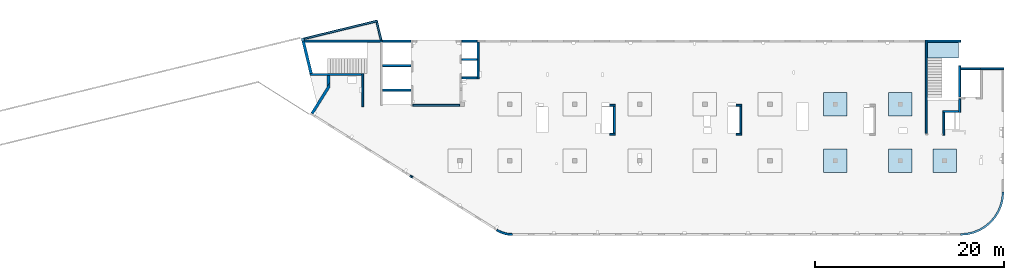
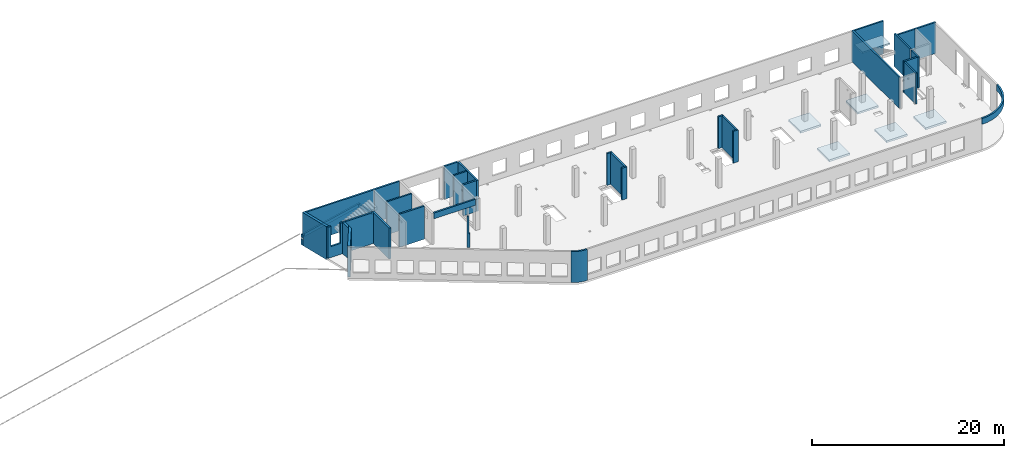
# One storey, part 2 of 7: 34 walls, 6 slabs, 2 openings.
"""IFC4 building model written with IfcOpenShell, lengths in millimetres."""

from ifc_helpers import new_model, entity, si_unit, converted_unit, derived_unit, direction, frame, origin, place, context, subcontext, project, spatial, indexed_curve, outline, extrude, polygons, material, type_object, element, save


model = new_model("IFC4")

# Units and contexts
model_context = context("Model", 3, precision=0.01, world=origin(), true_north=direction((6.12303176911189e-17, 1.0)))
plan_context = context("Plan", 3, precision=0.01, world=origin(), true_north=direction((6.12303176911189e-17, 1.0)))
body_context = subcontext(model_context, "Body", "Model", "MODEL_VIEW")
ifc_project = project(units=[si_unit("LENGTHUNIT", "METRE", prefix="MILLI"), si_unit("AREAUNIT", "SQUARE_METRE"), si_unit("VOLUMEUNIT", "CUBIC_METRE"), converted_unit("PLANEANGLEUNIT", "DEGREE", entity("IfcRatioMeasure", 0.0174532925199433), si_unit("PLANEANGLEUNIT", "RADIAN"), dimensions=[0, 0, 0, 0, 0, 0, 0]), si_unit("MASSUNIT", "GRAM", prefix="KILO"), derived_unit("MASSDENSITYUNIT", [(si_unit("MASSUNIT", "GRAM", prefix="KILO"), 1), (si_unit("LENGTHUNIT", "METRE"), -3)]), derived_unit("MOMENTOFINERTIAUNIT", [(si_unit("LENGTHUNIT", "METRE"), 4)]), si_unit("TIMEUNIT", "SECOND"), si_unit("FREQUENCYUNIT", "HERTZ"), si_unit("THERMODYNAMICTEMPERATUREUNIT", "DEGREE_CELSIUS"), derived_unit("THERMALTRANSMITTANCEUNIT", [(si_unit("MASSUNIT", "GRAM", prefix="KILO"), 1), (si_unit("THERMODYNAMICTEMPERATUREUNIT", "KELVIN"), -1), (si_unit("TIMEUNIT", "SECOND"), -3)]), derived_unit("VOLUMETRICFLOWRATEUNIT", [(si_unit("LENGTHUNIT", "METRE"), 3), (si_unit("TIMEUNIT", "SECOND"), -1)]), derived_unit("MASSFLOWRATEUNIT", [(si_unit("MASSUNIT", "GRAM", prefix="KILO"), 1), (si_unit("TIMEUNIT", "SECOND"), -1)]), derived_unit("ROTATIONALFREQUENCYUNIT", [(si_unit("TIMEUNIT", "SECOND"), -1)]), si_unit("ELECTRICCURRENTUNIT", "AMPERE"), si_unit("ELECTRICVOLTAGEUNIT", "VOLT"), si_unit("POWERUNIT", "WATT"), si_unit("FORCEUNIT", "NEWTON", prefix="KILO"), si_unit("ILLUMINANCEUNIT", "LUX"), si_unit("LUMINOUSFLUXUNIT", "LUMEN"), si_unit("LUMINOUSINTENSITYUNIT", "CANDELA"), derived_unit("USERDEFINED", [(si_unit("MASSUNIT", "GRAM", prefix="KILO"), -1), (si_unit("LENGTHUNIT", "METRE"), -2), (si_unit("TIMEUNIT", "SECOND"), 3), (si_unit("LUMINOUSFLUXUNIT", "LUMEN"), 1)]), derived_unit("LINEARVELOCITYUNIT", [(si_unit("LENGTHUNIT", "METRE"), 1), (si_unit("TIMEUNIT", "SECOND"), -1)]), si_unit("PRESSUREUNIT", "PASCAL"), derived_unit("USERDEFINED", [(si_unit("LENGTHUNIT", "METRE"), -2), (si_unit("MASSUNIT", "GRAM", prefix="KILO"), 1), (si_unit("TIMEUNIT", "SECOND"), -2)]), derived_unit("LINEARFORCEUNIT", [(si_unit("MASSUNIT", "GRAM", prefix="KILO"), 1), (si_unit("LENGTHUNIT", "METRE"), 1), (si_unit("TIMEUNIT", "SECOND"), -2), (si_unit("LENGTHUNIT", "METRE"), -1)]), derived_unit("PLANARFORCEUNIT", [(si_unit("MASSUNIT", "GRAM", prefix="KILO"), 1), (si_unit("LENGTHUNIT", "METRE"), 1), (si_unit("TIMEUNIT", "SECOND"), -2), (si_unit("LENGTHUNIT", "METRE"), -2)])], contexts=[model_context, plan_context])

# Site, building, storey
site_placement = place(None, origin())
site = spatial("IfcSite", under=ifc_project, at=site_placement, CompositionType="ELEMENT")
building_placement = place(site_placement, origin())
building = spatial("IfcBuilding", under=site, at=building_placement, CompositionType="ELEMENT")
storey_placement = place(building_placement, frame((0.0, 0.0, 24000.0)))
storey = spatial("IfcBuildingStorey", under=building, at=storey_placement, Name="07", CompositionType="ELEMENT", Elevation=24000.0)

# Slabs
ifc_material = material()
slab_type_1 = type_object("IfcSlabType", Name=":ADSK_ 25_250", PredefinedType="FLOOR", material=ifc_material)
placement_1 = place(storey_placement, origin())
element("IfcSlab", 1, at=placement_1, inside=storey, type_object=slab_type_1, material=ifc_material, Name=":ADSK_ 25_250", ObjectType=":ADSK_ 25_250", PredefinedType="FLOOR", context=body_context, shape_type="SweptSolid", body=[
    extrude(outline(indexed_curve([(-1250.0, -1249.99999999999), (1250.0, -1249.99999999999), (1250.0, 1250.00000000001), (-1250.0, 1250.00000000001), (-1250.0, -1249.99999999999)], self_intersect=False)), frame((55670.0, 7700.0, -400.0), z_axis=(0.0, 0.0, -1.0), x_axis=(0.0, 1.0, 0.0)), (0.0, 0.0, 1.0), 249.999999999999),
])
slab_type_2 = type_object("IfcSlabType", Name=":ADSK_ 25_250", PredefinedType="FLOOR", material=ifc_material)
element("IfcSlab", 2, at=placement_1, inside=storey, type_object=slab_type_2, material=ifc_material, Name=":ADSK_ 25_250", ObjectType=":ADSK_ 25_250", PredefinedType="FLOOR", context=body_context, shape_type="SweptSolid", body=[
    extrude(outline(indexed_curve([(-1250.0, -1250.0), (1250.0, -1250.0), (1250.0, 1250.0), (-1250.0, 1250.0), (-1250.0, -1250.0)], self_intersect=False)), frame((62570.0, 7700.0, -400.0), z_axis=(0.0, 0.0, -1.0), x_axis=(0.0, 1.0, 0.0)), (0.0, 0.0, 1.0), 249.999999999999),
])
slab_type_3 = type_object("IfcSlabType", Name=":ADSK_ 25_250", PredefinedType="FLOOR", material=ifc_material)
element("IfcSlab", 3, at=placement_1, inside=storey, type_object=slab_type_3, material=ifc_material, Name=":ADSK_ 25_250", ObjectType=":ADSK_ 25_250", PredefinedType="FLOOR", context=body_context, shape_type="SweptSolid", body=[
    extrude(outline(indexed_curve([(-1250.0, -1249.99999999999), (1250.0, -1249.99999999999), (1250.0, 1250.00000000001), (-1250.0, 1250.00000000001), (-1250.0, -1249.99999999999)], self_intersect=False)), frame((67270.0, 7700.0, -400.0), z_axis=(0.0, 0.0, -1.0), x_axis=(0.0, 1.0, 0.0)), (0.0, 0.0, 1.0), 249.999999999999),
])
slab_type_4 = type_object("IfcSlabType", Name=":ADSK_ 25_250", PredefinedType="FLOOR", material=ifc_material)
element("IfcSlab", 4, at=placement_1, inside=storey, type_object=slab_type_4, material=ifc_material, Name=":ADSK_ 25_250", ObjectType=":ADSK_ 25_250", PredefinedType="FLOOR", context=body_context, shape_type="SweptSolid", body=[
    extrude(outline(indexed_curve([(-1250.0, -1250.0), (1250.0, -1250.0), (1250.0, 1250.0), (-1250.0, 1250.0), (-1250.0, -1250.0)], self_intersect=False)), frame((62570.0, 13700.0, -400.0), z_axis=(0.0, 0.0, -1.0), x_axis=(0.0, 1.0, 0.0)), (0.0, 0.0, 1.0), 249.999999999999),
])
slab_type_5 = type_object("IfcSlabType", Name=":ADSK_ 25_250", PredefinedType="FLOOR", material=ifc_material)
element("IfcSlab", 5, at=placement_1, inside=storey, type_object=slab_type_5, material=ifc_material, Name=":ADSK_ 25_250", ObjectType=":ADSK_ 25_250", PredefinedType="FLOOR", context=body_context, shape_type="SweptSolid", body=[
    extrude(outline(indexed_curve([(-1250.0, -1250.0), (1250.0, -1250.0), (1250.0, 1250.0), (-1250.0, 1250.0), (-1250.0, -1250.0)], self_intersect=False)), frame((55670.0, 13700.0, -400.0), z_axis=(0.0, 0.0, -1.0), x_axis=(0.0, 1.0, 0.0)), (0.0, 0.0, 1.0), 249.999999999999),
])
slab_type_6 = type_object("IfcSlabType", Name=":ADSK_ 25_200", PredefinedType="FLOOR", material=ifc_material)
element("IfcSlab", 6, at=placement_1, inside=storey, type_object=slab_type_6, material=ifc_material, Name=":ADSK_ 25_200", ObjectType=":ADSK_ 25_200", PredefinedType="FLOOR", context=body_context, shape_type="SweptSolid", body=[
    extrude(outline(indexed_curve([(-834.999999999999, -1670.00000000001), (835.000000000001, -1670.00000000001), (835.000000000001, 1670.00000000002), (-834.999999999999, 1670.00000000002), (-834.999999999999, -1670.00000000001)], self_intersect=False)), frame((67100.0, 19465.0, 2070.0), z_axis=(0.0, 0.0, -1.0), x_axis=(0.0, 1.0, 0.0)), (0.0, 0.0, 1.0), 199.999999999998),
])

# Walls
wall_type_1 = type_object("IfcWallType", Name=":ADSK_ 25_200", PredefinedType="STANDARD")
wall_1_placement = place(storey_placement, frame((71070.0, 17470.0, -150.0)))
element("IfcWall", 7, at=wall_1_placement, inside=storey, type_object=wall_type_1, material=ifc_material, Name=":ADSK_ 25_200", ObjectType=":ADSK_ 25_200", PredefinedType="NOTDEFINED", context=body_context, shape_type="SweptSolid", body=[
    extrude(outline(indexed_curve([(2500.00000000001, 100.0), (-3.09390608370965e-13, 99.9999999999989), (3.09390608370965e-13, -99.9999999999989), (2500.00000000001, -99.9999999999977), (2500.00000000001, 100.0)], self_intersect=False)), origin(), (0.0, 0.0, 1.0), 3950.0),
])
wall_2_placement = place(storey_placement, frame((68870.0, 14270.0, -150.0), z_axis=(0.0, 0.0, 1.0), x_axis=(0.0, -1.0, 0.0)))
element("IfcWall", 8, at=wall_2_placement, inside=storey, type_object=wall_type_1, material=ifc_material, Name=":ADSK_ 25_200", ObjectType=":ADSK_ 25_200", PredefinedType="NOTDEFINED", context=body_context, shape_type="SweptSolid", body=[
    extrude(outline(indexed_curve([(1439.99999999999, 100.000000000003), (0.0, 100.000000000003), (0.0, -100.000000000003), (1439.99999999999, -100.000000000003), (1439.99999999999, 100.000000000003)], self_intersect=False)), origin(), (0.0, 0.0, 1.0), 3950.0),
])
wall_3_placement = place(storey_placement, frame((68770.0, 12930.0, -150.0), z_axis=(0.0, 0.0, 1.0), x_axis=(-1.0, 0.0, 0.0)))
element("IfcWall", 9, at=wall_3_placement, inside=storey, type_object=wall_type_1, material=ifc_material, Name=":ADSK_ 25_200", ObjectType=":ADSK_ 25_200", PredefinedType="NOTDEFINED", context=body_context, shape_type="SweptSolid", body=[
    extrude(outline(indexed_curve([(1689.99999999997, 99.9999999999989), (-3.84449868389964e-13, 99.9999999999989), (3.84449868389964e-13, -99.9999999999989), (1689.99999999997, -99.9999999999989), (1689.99999999997, 99.9999999999989)], self_intersect=False)), origin(), (0.0, 0.0, 1.0), 3950.0),
])
wall_4_placement = place(storey_placement, frame((67180.0, 12830.0, -150.0), z_axis=(0.0, 0.0, 1.0), x_axis=(0.0, -1.0, 0.0)))
element("IfcWall", 10, at=wall_4_placement, inside=storey, type_object=wall_type_1, material=ifc_material, Name=":ADSK_ 25_200", ObjectType=":ADSK_ 25_200", PredefinedType="NOTDEFINED", context=body_context, shape_type="SweptSolid", body=[
    extrude(outline(indexed_curve([(2404.99999999995, 100.000000000003), (0.0, 100.000000000003), (0.0, -100.000000000003), (2404.99999999995, -100.000000000003), (2404.99999999995, 100.000000000003)], self_intersect=False)), origin(), (0.0, 0.0, 1.0), 3950.0),
])
wall_5_placement = place(storey_placement, frame((65330.0, 10625.0, -150.0), z_axis=(0.0, 0.0, 1.0), x_axis=(0.0, 1.0, 0.0)))
element("IfcWall", 11, at=wall_5_placement, inside=storey, type_object=wall_type_1, material=ifc_material, Name=":ADSK_ 25_200", ObjectType=":ADSK_ 25_200", PredefinedType="NOTDEFINED", context=body_context, shape_type="SweptSolid", body=[
    extrude(outline(indexed_curve([(9875.00063936713, 100.000000000003), (-1.71685740578866e-13, 100.000000000003), (1.71685740578866e-13, -100.000000000003), (9875.00063936713, -100.000000000004), (9875.00063936713, 100.000000000003)], self_intersect=False)), origin(), (0.0, 0.0, 1.0), 3950.0),
])
wall_6_placement = place(storey_placement, frame((68970.0, -100.0, 3050.0)))
element("IfcWall", 12, at=wall_6_placement, inside=storey, type_object=wall_type_1, material=ifc_material, Name=":ADSK_ 25_200", ObjectType=":ADSK_ 25_200", PredefinedType="NOTDEFINED", context=body_context, shape_type="SweptSolid", body=[
    extrude(outline(indexed_curve([(4399.99918212903, 4499.99918212888), (4345.82789081698, 3811.68766389508), (4184.64789385715, 3140.32465961517), (3920.42797770043, 2502.44135458057), (3559.67411357824, 1913.74455277455), (3111.26925889869, 1388.72992323025), (2586.25462935438, 940.325068550716), (1997.55782754836, 579.571204428538), (1359.67452251375, 315.351288271842), (688.311518233829, 154.171291312031), (3.46517481375486e-11, 100.0), (0.0, -100.0), (719.598411241839, -43.3663768070014), (1421.47792138871, 125.139985012801), (2088.35592749623, 401.369899590849), (2703.81167981284, 778.521669675706), (3252.69061513597, 1247.30856699292), (3721.47751245321, 1796.18750231603), (4098.6292825381, 2411.64325463263), (4374.85919711618, 3078.52126074015), (4543.365558936, 3780.40077088701), (4599.99918212903, 4499.99918212885), (4399.99918212903, 4499.99918212888)], self_intersect=False)), origin(), (0.0, 0.0, 1.0), 750.000000000003),
])
wall_7_placement = place(storey_placement, frame((17825.0, 20300.0, -150.0), z_axis=(0.0, 0.0, 1.0), x_axis=(0.0, -1.0, 0.0)))
element("IfcWall", 13, at=wall_7_placement, inside=storey, type_object=wall_type_1, material=ifc_material, Name=":ADSK_ 25_200", ObjectType=":ADSK_ 25_200", PredefinedType="NOTDEFINED", context=body_context, shape_type="SweptSolid", body=[
    extrude(outline(indexed_curve([(3900.00063936684, 99.9999999999989), (-1.66594915657375e-13, 99.9999999999989), (1.66594915657375e-13, -99.9999999999989), (3900.00063936684, -99.9999999999989), (3900.00063936684, 99.9999999999989)], self_intersect=False)), origin(), (0.0, 0.0, 1.0), 3950.0),
])
wall_8_placement = place(storey_placement, frame((17725.0, 16500.0, -150.0), z_axis=(0.0, 0.0, 1.0), x_axis=(-1.0, 0.0, 0.0)))
element("IfcWall", 14, at=wall_8_placement, inside=storey, type_object=wall_type_1, material=ifc_material, Name=":ADSK_ 25_200", ObjectType=":ADSK_ 25_200", PredefinedType="NOTDEFINED", context=body_context, shape_type="SweptSolid", body=[
    extrude(outline(indexed_curve([(1624.99999999999, 99.9999999999982), (-3.56011111002209e-13, 99.9999999999989), (3.56011111002209e-13, -99.9999999999989), (1624.99999999999, -99.9999999999996), (1624.99999999999, 99.9999999999982)], self_intersect=False)), origin(), (0.0, 0.0, 1.0), 3950.0),
])
wall_9_placement = place(storey_placement, frame((5600.0, 13450.0, -150.0), z_axis=(0.0, 0.0, 1.0), x_axis=(0.0, 1.0, 0.0)))
element("IfcWall", 15, at=wall_9_placement, inside=storey, type_object=wall_type_1, material=ifc_material, Name=":ADSK_ 25_200", ObjectType=":ADSK_ 25_200", PredefinedType="NOTDEFINED", context=body_context, shape_type="SweptSolid", body=[
    extrude(outline(indexed_curve([(3510.00000000004, 100.000000000001), (-1.37676332088153e-13, 100.0), (1.37676332088153e-13, -100.0), (3510.00000000004, -99.9999999999995), (3510.00000000004, 100.000000000001)], self_intersect=False)), origin(), (0.0, 0.0, 1.0), 3950.0),
])

# Wall, opening
wall_10_placement = place(storey_placement, frame((-29.47, 16860.0, -150.0)))
wall_10 = element("IfcWall", 16, at=wall_10_placement, inside=storey, type_object=wall_type_1, material=ifc_material, Name=":ADSK_ 25_200", ObjectType=":ADSK_ 25_200", PredefinedType="NOTDEFINED", context=body_context, shape_type="Tessellation", body=[
    polygons([(48.7521159583314, -100.000000000001, 0.0), (1834.46650967482, -100.000000000001, 0.0), (2134.46650967482, -100.000000000001, 0.0), (5529.46650967482, -100.000000000001, 0.0), (5529.46650967482, -100.000000000001, 3950.0), (2134.46650967482, -100.000000000001, 3950.0), (1834.46650967482, -100.000000000001, 3950.0), (1559.46650967482, -100.000000000003, 3950.0), (1559.46650967482, -100.000000000003, 1400.00000000001), (459.466509674821, -99.9999999999989, 1400.00000000001), (459.466509674821, -100.000000000001, 3950.0), (48.7521159583309, -100.000000000001, 3950.0), (5529.46650967482, 99.9999999999989, 0.0), (-7.70689933091983e-14, 99.9999999999989, 0.0), (-7.70689933091983e-14, 99.9999999999989, 3950.0), (308.784277163577, 99.9999999999989, 3950.0), (459.466509674821, 99.9999999999989, 3950.0), (459.466509674822, 100.000000000319, 1400.00000000001), (1559.46650967482, 100.000000000319, 1400.00000000001), (1559.46650967482, 99.9999999999989, 3950.0), (1834.46650967482, 99.9999999999989, 3950.0), (5529.46650967482, 99.9999999999989, 3950.0)], [[[1, 2, 3, 4, 5, 6, 7, 8, 9, 10, 11, 12]], [[13, 14, 15, 16, 17, 18, 19, 20, 21, 22]], [[4, 3, 2, 1, 14, 13]], [[5, 22, 21, 20, 8, 7, 6]], [[5, 4, 13, 22]], [[1, 12, 15, 14]], [[10, 18, 17, 11]], [[18, 10, 9, 19]], [[19, 9, 8, 20]], [[15, 12, 11, 17, 16]]], closed=True),
])
opening_1_placement = place(wall_10_placement, origin())
element("IfcOpeningElement", 17, at=opening_1_placement, cuts=wall_10, Name=":ADSK_ 25_200", PredefinedType="OPENING", context=body_context, shape_type="SweptSolid", body=[
    extrude(outline(indexed_curve([(-3150.0, -550.0), (3149.99999999999, -550.0), (3149.99999999999, 550.0), (-3150.0, 550.0), (-3150.0, -550.0)], self_intersect=False)), frame((1009.47, -100.0, 4550.0), z_axis=(0.0, 1.0, 0.0), x_axis=(0.0, 0.0, -1.0)), (0.0, 0.0, 1.0), 200.000000000962),
])

# Walls
wall_11_placement = place(storey_placement, frame((7700.0, 20400.0, -150.0), z_axis=(0.0, 0.0, 1.0), x_axis=(-1.0, 0.0, 0.0)))
element("IfcWall", 18, at=wall_11_placement, inside=storey, type_object=wall_type_1, material=ifc_material, Name=":ADSK_ 25_200", ObjectType=":ADSK_ 25_200", PredefinedType="NOTDEFINED", context=body_context, shape_type="SweptSolid", body=[
    extrude(outline(indexed_curve([(8283.59484082612, -100.000000000002), (8234.84272486779, 100.0), (200.0, 99.9999999999996), (-3.3419311609182e-13, 99.9999999999989), (3.34193116091834e-13, -100.000000000003), (8283.59484082612, -100.000000000002)], self_intersect=False)), origin(), (0.0, 0.0, 1.0), 3950.0),
])
wall_12_placement = place(storey_placement, frame((68870.0, 17780.0, -400.0), z_axis=(0.0, 0.0, 1.0), x_axis=(0.0, -1.0, 0.0)))
element("IfcWall", 19, at=wall_12_placement, inside=storey, type_object=wall_type_1, material=ifc_material, Name=":ADSK_ 25_200", ObjectType=":ADSK_ 25_200", PredefinedType="NOTDEFINED", context=body_context, shape_type="SweptSolid", body=[
    extrude(outline(indexed_curve([(3310.0, 100.000000000003), (0.0, 100.000000000003), (0.0, -100.000000000003), (3310.0, -100.000000000003), (3310.0, 100.000000000003)], self_intersect=False)), origin(), (0.0, 0.0, 1.0), 4200.0),
])
wall_13_placement = place(storey_placement, frame((68970.0, 17470.0, -400.0)))
element("IfcWall", 20, at=wall_13_placement, inside=storey, type_object=wall_type_1, material=ifc_material, Name=":ADSK_ 25_200", ObjectType=":ADSK_ 25_200", PredefinedType="NOTDEFINED", context=body_context, shape_type="SweptSolid", body=[
    extrude(outline(indexed_curve([(2099.99918212888, 99.9999999999989), (-3.09390728867033e-13, 99.9999999999989), (3.09390728867033e-13, -99.9999999999989), (2099.99918212888, -99.9999999999989), (2099.99918212888, 99.9999999999989)], self_intersect=False)), origin(), (0.0, 0.0, 1.0), 4200.0),
])
wall_14_placement = place(storey_placement, frame((65430.0, 20400.0, -400.0)))
element("IfcWall", 21, at=wall_14_placement, inside=storey, type_object=wall_type_1, material=ifc_material, Name=":ADSK_ 25_200", ObjectType=":ADSK_ 25_200", PredefinedType="NOTDEFINED", context=body_context, shape_type="SweptSolid", body=[
    extrude(outline(indexed_curve([(3539.99999999995, 99.9999999999989), (-3.67073603151997e-13, 99.9999999999989), (3.67073603151997e-13, -99.9999999999989), (3539.99999999995, -99.9999999999989), (3539.99999999995, 99.9999999999989)], self_intersect=False)), origin(), (0.0, 0.0, 1.0), 4200.0),
])
wall_15_placement = place(storey_placement, frame((16100.0, 20400.0, -400.0)))
element("IfcWall", 22, at=wall_15_placement, inside=storey, type_object=wall_type_1, material=ifc_material, Name=":ADSK_ 25_200", ObjectType=":ADSK_ 25_200", PredefinedType="NOTDEFINED", context=body_context, shape_type="SweptSolid", body=[
    extrude(outline(indexed_curve([(1624.99999999999, 99.9999999999989), (-2.66551908750372e-13, 99.9999999999989), (2.66551908750372e-13, -99.9999999999989), (1624.99999999999, -99.9999999999989), (1624.99999999999, 99.9999999999989)], self_intersect=False)), origin(), (0.0, 0.0, 1.0), 4200.0),
])
wall_16_placement = place(storey_placement, frame((16100.0, 18450.0, -400.0)))
element("IfcWall", 23, at=wall_16_placement, inside=storey, type_object=wall_type_1, material=ifc_material, Name=":ADSK_ 25_200", ObjectType=":ADSK_ 25_200", PredefinedType="NOTDEFINED", context=body_context, shape_type="SweptSolid", body=[
    extrude(outline(indexed_curve([(1624.99999999999, 99.9999999999989), (-2.66551908750371e-13, 99.9999999999989), (2.66551908750371e-13, -99.9999999999989), (1624.99999999999, -99.9999999999989), (1624.99999999999, 99.9999999999989)], self_intersect=False)), origin(), (0.0, 0.0, 1.0), 4200.0),
])
for number, where, name in (
    (24, (7700.0, 20400.0, -400.0), ":ADSK_ 25_200"),
    (25, (7700.0, 17800.0, -400.0), ":ADSK_ 25_200"),
    (26, (7700.0, 15200.0, -400.0), ":ADSK_ 25_200"),
):
    element("IfcWall", number, at=place(storey_placement, frame(where)), inside=storey, type_object=wall_type_1, material=ifc_material, Name=name, ObjectType=":ADSK_ 25_200", PredefinedType="NOTDEFINED", context=body_context, shape_type="SweptSolid", body=[
        extrude(outline(indexed_curve([(3000.0, 99.9999999999989), (-2.88764567812902e-13, 99.9999999999989), (2.88764567812902e-13, -99.9999999999989), (3000.0, -99.9999999999989), (3000.0, 99.9999999999989)], self_intersect=False)), origin(), (0.0, 0.0, 1.0), 4200.0),
    ])
wall_17_placement = place(storey_placement, frame((7154.28, 22536.28, 550.0), z_axis=(0.0, 0.0, 1.0), x_axis=(-0.971552058141472, -0.23682609299034, 0.0)))
element("IfcWall", 27, at=wall_17_placement, inside=storey, type_object=wall_type_1, material=ifc_material, Name=":ADSK_ 25_200", ObjectType=":ADSK_ 25_200", PredefinedType="NOTDEFINED", context=body_context, shape_type="SweptSolid", body=[
    extrude(outline(indexed_curve([(7999.9920696628, 100.000000000002), (3.63775676248679e-13, 100.0), (-3.63775676248679e-13, -100.0), (7999.9920696628, -99.9999999999981), (7999.9920696628, 100.000000000002)], self_intersect=False)), origin(), (0.0, 0.0, 1.0), 399.999999999996),
])
wall_18_placement = place(storey_placement, frame((7080.81, 22415.44, 550.0), z_axis=(0.0, 0.0, 1.0), x_axis=(0.236826092990339, -0.971552058141473, 0.0)))
element("IfcWall", 28, at=wall_18_placement, inside=storey, type_object=wall_type_1, material=ifc_material, Name=":ADSK_ 25_200", ObjectType=":ADSK_ 25_200", PredefinedType="NOTDEFINED", context=body_context, shape_type="SweptSolid", body=[
    extrude(outline(indexed_curve([(1947.15147947281, -100.0), (1995.90359543114, 100.0), (1.29436461548949e-12, 99.9999999999997), (-1.29436461548949e-12, -99.9999999999997), (1947.15147947281, -100.0)], self_intersect=False)), origin(), (0.0, 0.0, 1.0), 399.999999999996),
])
wall_19_placement = place(storey_placement, frame((10900.0, 13600.0, 3050.0)))
element("IfcWall", 29, at=wall_19_placement, inside=storey, type_object=wall_type_1, material=ifc_material, Name=":ADSK_ 25_200", ObjectType=":ADSK_ 25_200", PredefinedType="NOTDEFINED", context=body_context, shape_type="SweptSolid", body=[
    extrude(outline(indexed_curve([(4999.99925537109, 99.9999999999989), (-3.03202841358267e-13, 99.9999999999989), (3.03202841358267e-13, -99.9999999999989), (4999.99925537109, -99.9999999999989), (4999.99925537109, 99.9999999999989)], self_intersect=False)), origin(), (0.0, 0.0, 1.0), 750.000000000003),
])
wall_20_placement = place(storey_placement, frame((19823.51, 370.44, -150.0)))
element("IfcWall", 30, at=wall_20_placement, inside=storey, type_object=wall_type_1, material=ifc_material, Name=":ADSK_ 25_200", ObjectType=":ADSK_ 25_200", PredefinedType="NOTDEFINED", context=body_context, shape_type="SweptSolid", body=[
    extrude(outline(indexed_curve([(1636.18152272799, -370.436490916867), (1469.39400500718, -365.506962801141), (1303.13894981314, -351.307211488465), (1137.93120555103, -327.881209893275), (974.282377378058, -295.301502213076), (812.699242896213, -253.668979278045), (653.682182794613, -203.112566118521), (497.723631301422, -143.788822717928), (345.306551243918, -75.8814591874654), (196.902938438973, 0.399233136038819), (52.9723600454957, 84.8170329073716), (-52.9723600454827, -84.8170329073819), (100.558460175235, -174.865542298412), (258.860668447987, -256.234195090284), (421.444044253667, -328.671013855484), (587.805109417498, -391.951680719459), (757.42868724919, -445.880232014374), (929.789497910372, -490.289665127326), (1104.35378506879, -525.042455663733), (1280.58096880202, -550.030983324403), (1457.92531963205, -565.177865177442), (1635.83764850666, -570.436195292948), (1636.18152272799, -370.436490916867)], self_intersect=False)), origin(), (0.0, 0.0, 1.0), 3950.0),
])
wall_21_placement = place(storey_placement, frame((31770.0, 13600.0, 0.0)))
element("IfcWall", 31, at=wall_21_placement, inside=storey, type_object=wall_type_1, material=ifc_material, Name=":ADSK_ 25_200", ObjectType=":ADSK_ 25_200", PredefinedType="NOTDEFINED", context=body_context, shape_type="SweptSolid", body=[
    extrude(outline(indexed_curve([(600.000000000002, 100.0), (-5.41433564649185e-13, 99.9999999999989), (5.41433564649185e-13, -99.9999999999989), (600.000000000003, -99.9999999999978), (600.000000000002, 100.0)], self_intersect=False)), origin(), (0.0, 0.0, 1.0), 4050.0),
])
wall_22_placement = place(storey_placement, frame((32270.0, 13500.0, 0.0), z_axis=(0.0, 0.0, 1.0), x_axis=(0.0, -1.0, 0.0)))
element("IfcWall", 32, at=wall_22_placement, inside=storey, type_object=wall_type_1, material=ifc_material, Name=":ADSK_ 25_200", ObjectType=":ADSK_ 25_200", PredefinedType="NOTDEFINED", context=body_context, shape_type="SweptSolid", body=[
    extrude(outline(indexed_curve([(2874.99985044025, 99.9999999999989), (-1.50659782348519e-13, 99.9999999999989), (1.50659782348519e-13, -99.9999999999989), (2874.99985044025, -99.9999999999989), (2874.99985044025, 99.9999999999989)], self_intersect=False)), origin(), (0.0, 0.0, 1.0), 4050.0),
])
wall_23_placement = place(storey_placement, frame((32370.0, 10525.0, 0.0), z_axis=(0.0, 0.0, 1.0), x_axis=(-1.0, 0.0, 0.0)))
element("IfcWall", 33, at=wall_23_placement, inside=storey, type_object=wall_type_1, material=ifc_material, Name=":ADSK_ 25_200", ObjectType=":ADSK_ 25_200", PredefinedType="NOTDEFINED", context=body_context, shape_type="SweptSolid", body=[
    extrude(outline(indexed_curve([(599.999999999993, 99.9999999999978), (-5.41433564649196e-13, 99.9999999999989), (5.41433564649196e-13, -99.9999999999989), (599.999999999994, -100.0), (599.999999999993, 99.9999999999978)], self_intersect=False)), origin(), (0.0, 0.0, 1.0), 4050.0),
])
wall_24_placement = place(storey_placement, frame((45170.0, 13600.0, 0.0)))
element("IfcWall", 34, at=wall_24_placement, inside=storey, type_object=wall_type_1, material=ifc_material, Name=":ADSK_ 25_200", ObjectType=":ADSK_ 25_200", PredefinedType="NOTDEFINED", context=body_context, shape_type="SweptSolid", body=[
    extrude(outline(indexed_curve([(600.000000000002, 99.9999999999978), (-5.41433564649196e-13, 99.9999999999989), (5.41433564649196e-13, -99.9999999999989), (600.000000000003, -100.0), (600.000000000002, 99.9999999999978)], self_intersect=False)), origin(), (0.0, 0.0, 1.0), 4050.0),
])
wall_25_placement = place(storey_placement, frame((45670.0, 13500.0, 0.0), z_axis=(0.0, 0.0, 1.0), x_axis=(0.0, -1.0, 0.0)))
element("IfcWall", 35, at=wall_25_placement, inside=storey, type_object=wall_type_1, material=ifc_material, Name=":ADSK_ 25_200", ObjectType=":ADSK_ 25_200", PredefinedType="NOTDEFINED", context=body_context, shape_type="SweptSolid", body=[
    extrude(outline(indexed_curve([(2874.99985044015, 100.000000000003), (-3.01319564697061e-13, 100.000000000003), (3.01319564697061e-13, -100.000000000003), (2874.99985044015, -100.000000000003), (2874.99985044015, 100.000000000003)], self_intersect=False)), origin(), (0.0, 0.0, 1.0), 4050.0),
])
wall_26_placement = place(storey_placement, frame((45770.0, 10525.0, 0.0), z_axis=(0.0, 0.0, 1.0), x_axis=(-1.0, 0.0, 0.0)))
element("IfcWall", 36, at=wall_26_placement, inside=storey, type_object=wall_type_1, material=ifc_material, Name=":ADSK_ 25_200", ObjectType=":ADSK_ 25_200", PredefinedType="NOTDEFINED", context=body_context, shape_type="SweptSolid", body=[
    extrude(outline(indexed_curve([(600.000000000002, 99.9999999999978), (-5.41433564649196e-13, 99.9999999999989), (5.41433564649196e-13, -99.9999999999989), (600.000000000003, -100.0), (600.000000000002, 99.9999999999978)], self_intersect=False)), origin(), (0.0, 0.0, 1.0), 4050.0),
])
wall_type_2 = type_object("IfcWallType", Name=":ADSK_ 25_300", PredefinedType="STANDARD")
wall_27_placement = place(storey_placement, frame((233.05, 12729.59, -150.0), z_axis=(0.0, 0.0, 1.0), x_axis=(0.529911826412024, 0.848052743777575, 0.0)))
element("IfcWall", 37, at=wall_27_placement, inside=storey, type_object=wall_type_2, material=ifc_material, Name=":ADSK_ 25_300", ObjectType=":ADSK_ 25_300", PredefinedType="NOTDEFINED", context=body_context, shape_type="SweptSolid", body=[
    extrude(outline(indexed_curve([(3292.51411367558, -150.000000000001), (3772.623842224, 150.0), (3206.4919216906, 150.0), (1.58200119670937e-12, 150.0), (9.05209240897875e-13, -150.0), (3292.51411367558, -150.000000000001)], self_intersect=False)), origin(), (0.0, 0.0, 1.0), 3950.0),
])
wall_28_placement = place(storey_placement, frame((-746.65, 20535.52, -400.0), z_axis=(0.0, 0.0, 1.0), x_axis=(0.236826092990339, -0.971552058141473, 0.0)))
element("IfcWall", 38, at=wall_28_placement, inside=storey, type_object=wall_type_2, material=ifc_material, Name=":ADSK_ 25_300", ObjectType=":ADSK_ 25_300", PredefinedType="NOTDEFINED", context=body_context, shape_type="Tessellation", body=[
    polygons([(139.492179356616, -150.0, 0.0), (3467.29257433501, -150.000000000001, 0.0), (3643.65512861822, -150.000000000001, 0.0), (3643.65512861822, -150.000000000001, 249.999999999999), (3643.65512861822, -150.000000000001, 4200.0), (205.856184775741, -150.000000000001, 4200.0), (-4.33146851719357e-12, -150.000000000001, 4200.0), (-4.33146851719357e-12, -150.000000000001, 1350.0), (139.492179356616, -150.0, 1350.0), (139.492179356616, -150.000000000001, 950.000000000001), (205.856184775733, -149.999999999994, 950.000000000001), (205.856184775733, -149.999999999994, 749.999999999998), (139.492179356616, -150.000000000001, 749.999999999998), (3716.78330255572, 149.999999999999, 0.0), (3467.29257433501, 149.999999999999, 0.0), (139.492179356611, 149.999999999999, 0.0), (139.492179356611, 149.999999999999, 749.999999999998), (278.984358713227, 149.999999999999, 749.999999999998), (278.984358713227, 149.999999999998, 950.000000000001), (139.492179356611, 149.999999999999, 950.000000000001), (139.492179356611, 149.999999999999, 1350.0), (73.1281739374943, 149.999999999999, 1350.0), (73.1281739374986, 149.999999999999, 4200.0), (278.984358713223, 149.999999999999, 4200.0), (3716.78330255572, 149.999999999999, 4200.0), (3716.78330255572, 149.999999999999, 2470.0), (3716.78330255572, 149.999999999999, 2270.0)], [[[1, 2, 3, 4, 5, 6, 7, 8, 9, 10, 11, 12, 13]], [[14, 15, 16, 17, 18, 19, 20, 21, 22, 23, 24, 25, 26, 27]], [[3, 2, 1, 16, 15, 14]], [[7, 6, 5, 25, 24, 23]], [[5, 4, 3, 14, 27, 26, 25]], [[9, 21, 20, 10]], [[22, 21, 9, 8]], [[8, 7, 23, 22]], [[12, 18, 17, 13]], [[19, 11, 10, 20]], [[18, 12, 11, 19]], [[16, 1, 13, 17]]], closed=True),
])
wall_29_placement = place(storey_placement, frame((1955.0, 16760.0, -150.0), z_axis=(0.0, 0.0, 1.0), x_axis=(0.0, -1.0, 0.0)))
element("IfcWall", 39, at=wall_29_placement, inside=storey, type_object=wall_type_2, material=ifc_material, Name=":ADSK_ 25_300", ObjectType=":ADSK_ 25_300", PredefinedType="NOTDEFINED", context=body_context, shape_type="SweptSolid", body=[
    extrude(outline(indexed_curve([(1231.64683521102, -150.0), (751.537106662604, 150.0), (-2.44623692705516e-13, 150.0), (2.44623692705516e-13, -150.0), (1231.64683521102, -150.0)], self_intersect=False)), origin(), (0.0, 0.0, 1.0), 3950.0),
])

# Wall, opening
placement_2 = place(storey_placement, frame((-787.54, 20703.3, -400.0), z_axis=(0.0, 0.0, 1.0), x_axis=(0.236826092990258, -0.971552058141492, 0.0)))
wall_30 = element("IfcWall", 40, at=placement_2, inside=storey, type_object=wall_type_2, material=ifc_material, Name=":ADSK_ 25_300", ObjectType=":ADSK_ 25_300", PredefinedType="NOTDEFINED", context=body_context, shape_type="SweptSolid", body=[
    extrude(outline(indexed_curve([(312.184895620594, 150.0), (5.66813262992127e-13, 150.0), (-5.66813262992127e-13, -150.0), (312.184895620592, -150.0), (312.184895620594, 150.0)], self_intersect=False)), origin(), (0.0, 0.0, 1.0), 1350.00000000001),
])
element("IfcOpeningElement", 41, at=placement_2, cuts=wall_30, Name=":ADSK_ 25_300:1", PredefinedType="OPENING", context=body_context, shape_type="SweptSolid", body=[
    extrude(outline(indexed_curve([(-156.092447810279, -149.999999999999), (156.092447810287, -149.999999999999), (156.092447810288, 150.000000000001), (-156.092447810305, 150.0), (-156.092447810279, -149.999999999999)], self_intersect=False)), frame((156.09, 0.0, 750.0)), (0.0, 0.0, 1.0), 200.000000000002),
])

# Wall
wall_type_3 = type_object("IfcWallType", Name="5: 5", PredefinedType="NOTDEFINED", material=ifc_material)
wall_31_placement = place(storey_placement, frame((10577.43, 5877.01, 4050.0)))
element("IfcWall", 42, at=wall_31_placement, inside=storey, type_object=wall_type_3, material=ifc_material, Name="5: 5", ObjectType="5: 5", PredefinedType="NOTDEFINED", context=body_context, shape_type="Tessellation", body=[
    polygons([(160.036576182802, 52.991182641201, 3950.0), (217.384704172807, 252.991182641207, 3950.0), (105.982365282413, 322.601731396727, 3950.0), (0.0, 152.991182641199, 3950.0), (0.0, 152.991182641199, 0.0), (105.982365282413, 322.601731396727, 0.0), (350.824215842971, 169.610548755526, 0.0), (244.841850560567, 1.29944055515807e-11, 0.0), (160.036576182802, 52.9911826411999, 1770.0), (217.384704172807, 252.991182641207, 1770.0), (350.824215842971, 169.610548755528, 1770.0), (244.841850560567, 1.40772726808791e-11, 1770.0)], [[[1, 2, 3, 4]], [[5, 6, 7, 8]], [[2, 1, 9, 10]], [[3, 2, 10, 11, 7, 6]], [[4, 3, 6, 5]], [[1, 4, 5, 8, 12, 9]], [[10, 9, 12, 11]], [[8, 7, 11, 12]]], closed=True),
])

save(model, "model.ifc")
